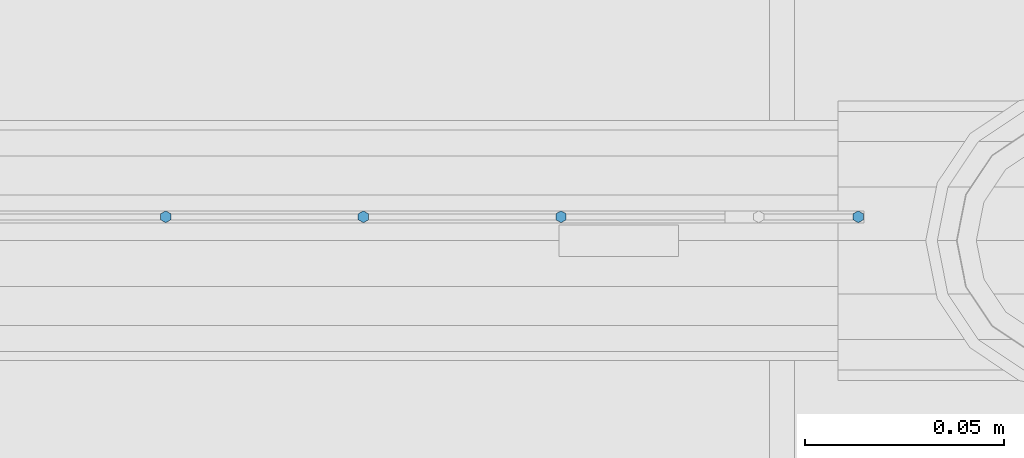
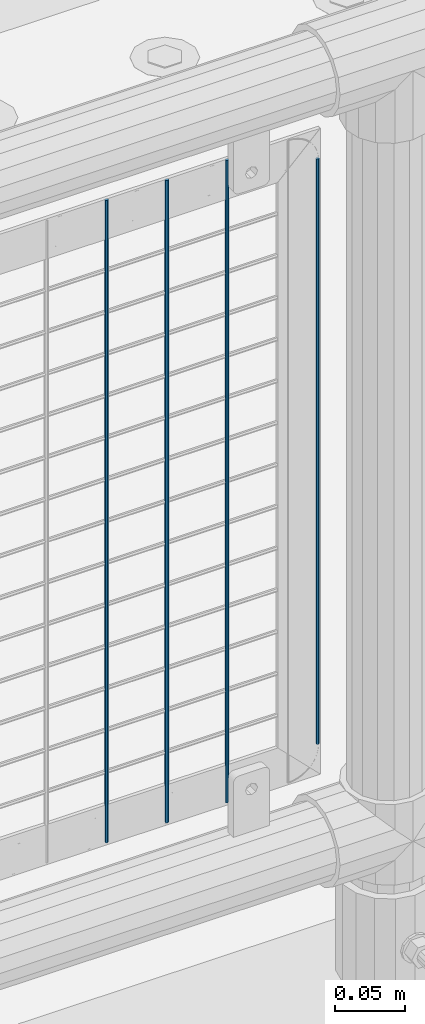
# One storey, part 91 of 247: 4 columns.
"""IFC2X3 building model written with IfcOpenShell, lengths in millimetres."""

from ifc_helpers import new_model, si_unit, frame, origin_with_axes, place, context, subcontext, project, spatial, faceted_brep, material, type_object, element, save


model = new_model("IFC2X3")

# Units and contexts
model_context = context("Model", 3, precision=1e-05, world=origin_with_axes())
body_context = subcontext(model_context, "Body", "Model", "MODEL_VIEW")
ifc_project = project(units=[si_unit("LENGTHUNIT", "METRE", prefix="MILLI"), si_unit("AREAUNIT", "SQUARE_METRE"), si_unit("VOLUMEUNIT", "CUBIC_METRE"), si_unit("MASSUNIT", "GRAM", prefix="KILO"), si_unit("TIMEUNIT", "SECOND"), si_unit("PLANEANGLEUNIT", "RADIAN"), si_unit("SOLIDANGLEUNIT", "STERADIAN"), si_unit("THERMODYNAMICTEMPERATUREUNIT", "DEGREE_CELSIUS"), si_unit("LUMINOUSINTENSITYUNIT", "LUMEN")], contexts=[model_context])

# Site, building, storey
site_placement = place(None, origin_with_axes())
site = spatial("IfcSite", under=ifc_project, at=site_placement, CompositionType="ELEMENT")
building_placement = place(site_placement, origin_with_axes())
building = spatial("IfcBuilding", under=site, at=building_placement, Name="Standard", CompositionType="ELEMENT")
storey_placement = place(building_placement, origin_with_axes())
storey = spatial("IfcBuildingStorey", under=building, at=storey_placement, Name="Undefined", CompositionType="ELEMENT", Elevation=0.0)

# Columns
ifc_material = material(Name="Misc_Undefined")
column_type = type_object("IfcColumnType", Name="D3", PredefinedType="NOTDEFINED")
for number, where, z_axis, x_axis in (
    (1, (10091.34, 7670.50000000001, 353.020000000003), (-1.0, 0.0, 0.0), (0.0, 0.0, 1.0)),
    (2, (10041.685, 7670.50000000001, 353.020000000003), (-1.0, 0.0, 0.0), (0.0, 0.0, 1.0)),
    (3, (9992.03, 7670.50000000001, 353.020000000003), (-1.0, 0.0, 0.0), (0.0, 0.0, 1.0)),
):
    element("IfcColumn", number, at=place(storey_placement, frame(where, z_axis=z_axis, x_axis=x_axis)), inside=storey, type_object=column_type, material=ifc_material, ObjectType="D3", context=body_context, shape_type="Brep", body=[
        faceted_brep([(1.81898940354586e-12, -1.5, -5.6843418860808e-14), (0.0, -0.75, -1.29903810567703), (560.0, -0.75, -1.29903810567703), (560.0, -1.5, 0.0), (0.0, 0.75, -1.29903810567703), (560.0, 0.75, -1.29903810567703), (1.81898940354586e-12, 1.5, -5.6843418860808e-14), (560.0, 1.5, 0.0), (0.0, 0.75, 1.29903810567703), (560.0, 0.75, 1.29903810567703), (0.0, -0.75, 1.29903810567703), (560.0, -0.75, 1.29903810567703)], [[[0, 1, 2, 3]], [[1, 4, 5, 2]], [[4, 6, 7, 5]], [[6, 8, 9, 7]], [[8, 10, 11, 9]], [[10, 0, 3, 11]], [[5, 7, 9, 11, 3, 2]], [[10, 8, 6, 4, 1, 0]]]),
    ])
column_placement = place(storey_placement, frame((10166.0, 7670.5, 378.020000000003), z_axis=(-1.0, 0.0, 0.0), x_axis=(0.0, 0.0, 1.0)))
element("IfcColumn", 4, at=column_placement, inside=storey, type_object=column_type, material=ifc_material, ObjectType="D3", context=body_context, shape_type="Brep", body=[
    faceted_brep([(1.81898940354586e-12, -1.5, -5.6843418860808e-14), (0.0, -0.75, -1.29903810567703), (510.0, -0.75, -1.29903810567703), (510.0, -1.5, 0.0), (0.0, 0.75, -1.29903810567703), (510.0, 0.75, -1.29903810567703), (1.81898940354586e-12, 1.5, -5.6843418860808e-14), (510.0, 1.5, 0.0), (0.0, 0.75, 1.29903810567703), (510.0, 0.75, 1.29903810567703), (0.0, -0.75, 1.29903810567703), (510.0, -0.75, 1.29903810567703)], [[[0, 1, 2, 3]], [[1, 4, 5, 2]], [[4, 6, 7, 5]], [[6, 8, 9, 7]], [[8, 10, 11, 9]], [[10, 0, 3, 11]], [[5, 7, 9, 11, 3, 2]], [[10, 8, 6, 4, 1, 0]]]),
])

save(model, "model.ifc")
